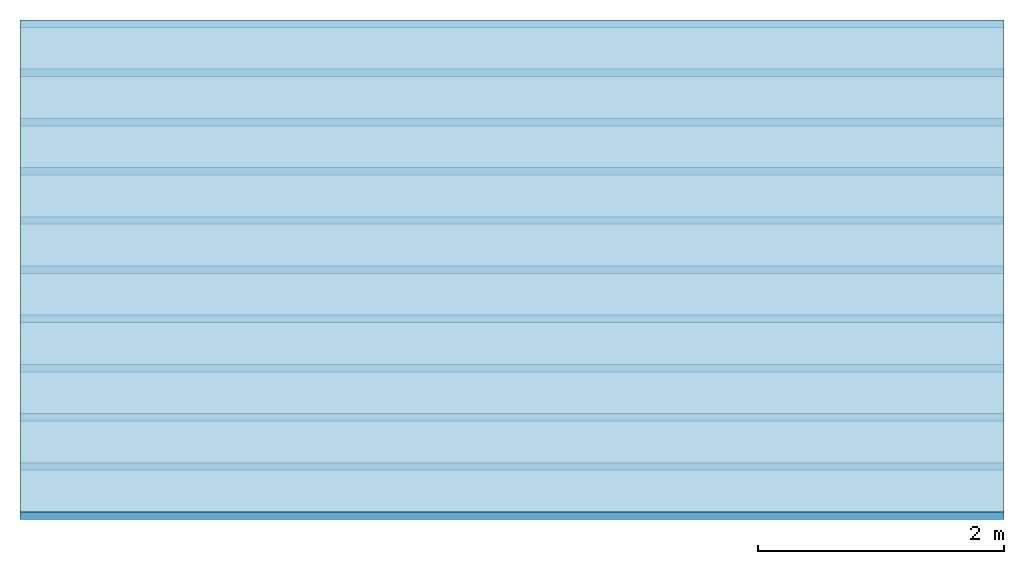
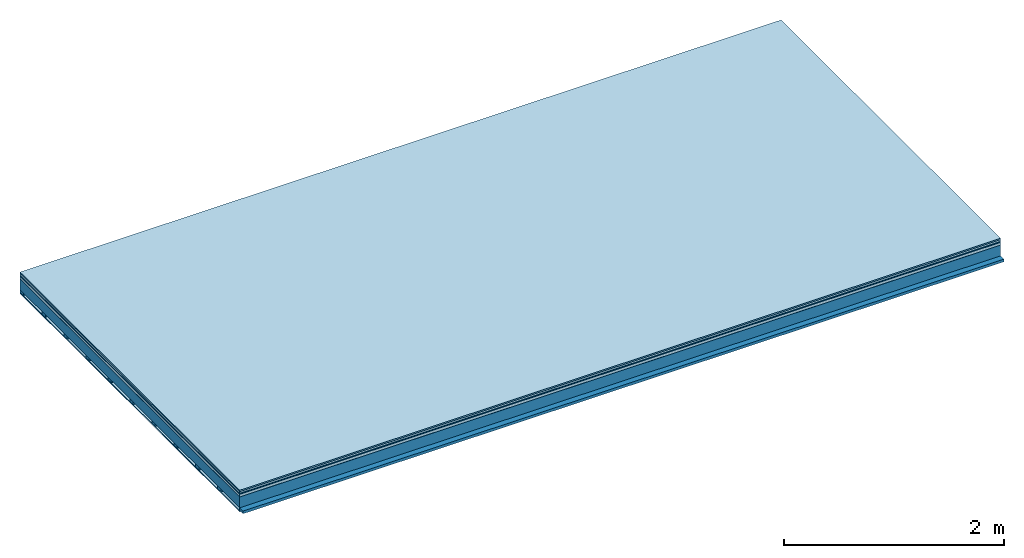
# One storey: 7 plates, 2 members, 1 element without a shape of its own.
"""IFC4 building model written with IfcOpenShell, lengths in metres."""

from ifc_helpers import new_model, si_unit, derived_unit, direction, frame, frame_2d, origin, origin_with_axes, place, context, project, spatial, rectangle, extrude, material, layer, layer_set, type_object, element, aggregate, save


model = new_model("IFC4")

# Units and contexts
plan_context = context("Plan", 3, precision=1e-05, world=origin(), true_north=direction((0.0, 1.0)))
model_context = context("Model", 3, precision=1e-05, world=origin(), true_north=direction((0.0, 1.0)))
ifc_project = project(units=[si_unit("LENGTHUNIT", "METRE"), derived_unit("SOUNDPRESSUREUNIT", [(si_unit("PRESSUREUNIT", "PASCAL", prefix="MICRO"), 0)]), si_unit("ENERGYUNIT", "JOULE", prefix="MEGA"), si_unit("MASSUNIT", "GRAM", prefix="KILO"), derived_unit("THERMALTRANSMITTANCEUNIT", [(si_unit("POWERUNIT", "WATT"), 1), (si_unit("AREAUNIT", "SQUARE_METRE"), -1), (si_unit("THERMODYNAMICTEMPERATUREUNIT", "KELVIN"), -1)]), derived_unit("AREADENSITYUNIT", [(si_unit("MASSUNIT", "GRAM", prefix="KILO"), 1), (si_unit("AREAUNIT", "SQUARE_METRE"), -1)]), derived_unit("USERDEFINED", [(si_unit("ENERGYUNIT", "JOULE", prefix="MEGA"), 1), (si_unit("AREAUNIT", "SQUARE_METRE"), -1)])], contexts=[plan_context, model_context])

# Site, building, storey
site = spatial("IfcSite", under=ifc_project)
building_placement = place(None, origin())
building = spatial("IfcBuilding", under=site, at=building_placement)
storey_placement = place(building_placement, origin())
storey = spatial("IfcBuildingStorey", under=building, at=storey_placement)

# Slab, members, plates
ifc_material_1 = material(Category="11.013")
ifc_layer_1 = layer(ifc_material_1, 0.015, Name="Flooring")
ifc_material_2 = material(Category="03.007")
ifc_layer_2 = layer(ifc_material_2, 0.02, Name="On-material")
ifc_material_3 = material(Name="Wood fiber generic product", Category="10.009")
ifc_layer_3 = layer(ifc_material_3, 0.01, Name="Impact sound insulation")
ifc_material_4 = material(Name="with broken")
ifc_layer_4 = layer(ifc_material_4, 0.03, Name="on Supporting structure")
ifc_material_5 = material(Name="protection", Category="09.007")
ifc_layer_5 = layer(ifc_material_5, 0.0005, Name="Sub-floor")
ifc_material_6 = material(Name="no composite action")
ifc_layer_6 = layer(ifc_material_6, 0.0, Name="Bond")
ifc_layer_7 = layer(None, 0.12, Name="Supporting structure")
ifc_material_7 = material(Name="of the art")
ifc_layer_8 = layer(ifc_material_7, 0.0, Name="Bond")
ifc_layer_9 = layer(None, 0.03, Name="Battens / profiles")
ifc_material_8 = material(Name="Plasterboard type A", Category="03.008")
ifc_layer_10 = layer(ifc_material_8, 0.0125, Name="Ceiling covering 1st layer")
ifc_material_9 = material(Category="04.001")
ifc_layer_11 = layer(ifc_material_9, 0.003, Name="Surface / treatment")
ifc_layer_set = layer_set([ifc_layer_1, ifc_layer_2, ifc_layer_3, ifc_layer_4, ifc_layer_5, ifc_layer_6, ifc_layer_7, ifc_layer_8, ifc_layer_9, ifc_layer_10, ifc_layer_11])
slab_type = type_object("IfcSlabType", Name="A2105", PredefinedType="NOTDEFINED", material=ifc_layer_set)
slab_placement = place(None, frame((0.0, 0.0, 0.0), z_axis=(0.0, 0.0, -1.0), x_axis=(1.0, 0.0, 0.0)))
slab = element("IfcSlab", 1, at=slab_placement, inside=storey, type_object=slab_type, material=ifc_layer_set, Name="Slab #1")
ifc_material_10 = material(Name="Solid timber panel")
member_1_placement = place(slab_placement, origin())
member_1 = element("IfcMember", 2, at=member_1_placement, material=ifc_material_10, Name="Supporting structure", context=plan_context, shape_type="SweptSolid", body=[
    extrude(rectangle(XDim=1.0, YDim=0.12, at=frame_2d((0.5, 0.06), x_axis=(1.0, 0.0))), frame((0.0, 4.0, 0.0755), z_axis=(0.0, -1.0, 0.0), x_axis=(1.0, 0.0, 0.0)), (0.0, 0.0, 1.0), 4.0),
    extrude(rectangle(XDim=1.0, YDim=0.12, at=frame_2d((0.5, 0.06), x_axis=(1.0, 0.0))), frame((1.0, 4.0, 0.0755), z_axis=(0.0, -1.0, 0.0), x_axis=(1.0, 0.0, 0.0)), (0.0, 0.0, 1.0), 4.0),
    extrude(rectangle(XDim=1.0, YDim=0.12, at=frame_2d((0.5, 0.06), x_axis=(1.0, 0.0))), frame((2.0, 4.0, 0.0755), z_axis=(0.0, -1.0, 0.0), x_axis=(1.0, 0.0, 0.0)), (0.0, 0.0, 1.0), 4.0),
    extrude(rectangle(XDim=1.0, YDim=0.12, at=frame_2d((0.5, 0.06), x_axis=(1.0, 0.0))), frame((3.0, 4.0, 0.0755), z_axis=(0.0, -1.0, 0.0), x_axis=(1.0, 0.0, 0.0)), (0.0, 0.0, 1.0), 4.0),
    extrude(rectangle(XDim=1.0, YDim=0.12, at=frame_2d((0.5, 0.06), x_axis=(1.0, 0.0))), frame((4.0, 4.0, 0.0755), z_axis=(0.0, -1.0, 0.0), x_axis=(1.0, 0.0, 0.0)), (0.0, 0.0, 1.0), 4.0),
    extrude(rectangle(XDim=1.0, YDim=0.12, at=frame_2d((0.5, 0.06), x_axis=(1.0, 0.0))), frame((5.0, 4.0, 0.0755), z_axis=(0.0, -1.0, 0.0), x_axis=(1.0, 0.0, 0.0)), (0.0, 0.0, 1.0), 4.0),
    extrude(rectangle(XDim=1.0, YDim=0.12, at=frame_2d((0.5, 0.06), x_axis=(1.0, 0.0))), frame((6.0, 4.0, 0.0755), z_axis=(0.0, -1.0, 0.0), x_axis=(1.0, 0.0, 0.0)), (0.0, 0.0, 1.0), 4.0),
    extrude(rectangle(XDim=1.0, YDim=0.12, at=frame_2d((0.5, 0.06), x_axis=(1.0, 0.0))), frame((7.0, 4.0, 0.0755), z_axis=(0.0, -1.0, 0.0), x_axis=(1.0, 0.0, 0.0)), (0.0, 0.0, 1.0), 4.0),
])
ifc_material_11 = material()
member_2_placement = place(slab_placement, origin())
member_2 = element("IfcMember", 3, at=member_2_placement, material=ifc_material_11, Name="Battens / profiles", context=plan_context, shape_type="SweptSolid", body=[
    extrude(rectangle(XDim=0.06, YDim=0.03, at=frame_2d((0.03, 0.015), x_axis=(1.0, 0.0))), frame((0.0, 0.0, 0.1955), z_axis=(1.0, 0.0, 0.0), x_axis=(0.0, 1.0, 0.0)), (0.0, 0.0, 1.0), 8.0),
    extrude(rectangle(XDim=0.06, YDim=0.03, at=frame_2d((0.03, 0.015), x_axis=(1.0, 0.0))), frame((0.0, 0.4, 0.1955), z_axis=(1.0, 0.0, 0.0), x_axis=(0.0, 1.0, 0.0)), (0.0, 0.0, 1.0), 8.0),
    extrude(rectangle(XDim=0.06, YDim=0.03, at=frame_2d((0.03, 0.015), x_axis=(1.0, 0.0))), frame((0.0, 0.8, 0.1955), z_axis=(1.0, 0.0, 0.0), x_axis=(0.0, 1.0, 0.0)), (0.0, 0.0, 1.0), 8.0),
    extrude(rectangle(XDim=0.06, YDim=0.03, at=frame_2d((0.03, 0.015), x_axis=(1.0, 0.0))), frame((0.0, 1.2, 0.1955), z_axis=(1.0, 0.0, 0.0), x_axis=(0.0, 1.0, 0.0)), (0.0, 0.0, 1.0), 8.0),
    extrude(rectangle(XDim=0.06, YDim=0.03, at=frame_2d((0.03, 0.015), x_axis=(1.0, 0.0))), frame((0.0, 1.6, 0.1955), z_axis=(1.0, 0.0, 0.0), x_axis=(0.0, 1.0, 0.0)), (0.0, 0.0, 1.0), 8.0),
    extrude(rectangle(XDim=0.06, YDim=0.03, at=frame_2d((0.03, 0.015), x_axis=(1.0, 0.0))), frame((0.0, 2.0, 0.1955), z_axis=(1.0, 0.0, 0.0), x_axis=(0.0, 1.0, 0.0)), (0.0, 0.0, 1.0), 8.0),
    extrude(rectangle(XDim=0.06, YDim=0.03, at=frame_2d((0.03, 0.015), x_axis=(1.0, 0.0))), frame((0.0, 2.4, 0.1955), z_axis=(1.0, 0.0, 0.0), x_axis=(0.0, 1.0, 0.0)), (0.0, 0.0, 1.0), 8.0),
    extrude(rectangle(XDim=0.06, YDim=0.03, at=frame_2d((0.03, 0.015), x_axis=(1.0, 0.0))), frame((0.0, 2.8, 0.1955), z_axis=(1.0, 0.0, 0.0), x_axis=(0.0, 1.0, 0.0)), (0.0, 0.0, 1.0), 8.0),
    extrude(rectangle(XDim=0.06, YDim=0.03, at=frame_2d((0.03, 0.015), x_axis=(1.0, 0.0))), frame((0.0, 3.2, 0.1955), z_axis=(1.0, 0.0, 0.0), x_axis=(0.0, 1.0, 0.0)), (0.0, 0.0, 1.0), 8.0),
    extrude(rectangle(XDim=0.06, YDim=0.03, at=frame_2d((0.03, 0.015), x_axis=(1.0, 0.0))), frame((0.0, 3.6, 0.1955), z_axis=(1.0, 0.0, 0.0), x_axis=(0.0, 1.0, 0.0)), (0.0, 0.0, 1.0), 8.0),
    extrude(rectangle(XDim=0.06, YDim=0.03, at=frame_2d((0.03, 0.015), x_axis=(1.0, 0.0))), frame((0.0, 4.0, 0.1955), z_axis=(1.0, 0.0, 0.0), x_axis=(0.0, 1.0, 0.0)), (0.0, 0.0, 1.0), 8.0),
])
plate_1_placement = place(slab_placement, origin())
plate_1 = element("IfcPlate", 4, at=plate_1_placement, material=ifc_material_1, Name="Flooring", context=plan_context, shape_type="SweptSolid", body=[
    extrude(rectangle(XDim=8.0, YDim=4.0, at=frame_2d((4.0, 2.0), x_axis=(1.0, 0.0))), origin_with_axes(), (0.0, 0.0, 1.0), 0.015),
])
plate_2_placement = place(slab_placement, origin())
plate_2 = element("IfcPlate", 5, at=plate_2_placement, material=ifc_material_2, Name="On-material", context=plan_context, shape_type="SweptSolid", body=[
    extrude(rectangle(XDim=8.0, YDim=4.0, at=frame_2d((4.0, 2.0), x_axis=(1.0, 0.0))), frame((0.0, 0.0, 0.015), z_axis=(0.0, 0.0, 1.0), x_axis=(1.0, 0.0, 0.0)), (0.0, 0.0, 1.0), 0.02),
])
plate_3_placement = place(slab_placement, origin())
plate_3 = element("IfcPlate", 6, at=plate_3_placement, material=ifc_material_3, Name="Impact sound insulation", context=plan_context, shape_type="SweptSolid", body=[
    extrude(rectangle(XDim=8.0, YDim=4.0, at=frame_2d((4.0, 2.0), x_axis=(1.0, 0.0))), frame((0.0, 0.0, 0.035), z_axis=(0.0, 0.0, 1.0), x_axis=(1.0, 0.0, 0.0)), (0.0, 0.0, 1.0), 0.01),
])
plate_4_placement = place(slab_placement, origin())
plate_4 = element("IfcPlate", 7, at=plate_4_placement, material=ifc_material_4, Name="on Supporting structure", context=plan_context, shape_type="SweptSolid", body=[
    extrude(rectangle(XDim=8.0, YDim=4.0, at=frame_2d((4.0, 2.0), x_axis=(1.0, 0.0))), frame((0.0, 0.0, 0.045), z_axis=(0.0, 0.0, 1.0), x_axis=(1.0, 0.0, 0.0)), (0.0, 0.0, 1.0), 0.03),
])
plate_5_placement = place(slab_placement, origin())
plate_5 = element("IfcPlate", 8, at=plate_5_placement, material=ifc_material_5, Name="Sub-floor", context=plan_context, shape_type="SweptSolid", body=[
    extrude(rectangle(XDim=8.0, YDim=4.0, at=frame_2d((4.0, 2.0), x_axis=(1.0, 0.0))), frame((0.0, 0.0, 0.075), z_axis=(0.0, 0.0, 1.0), x_axis=(1.0, 0.0, 0.0)), (0.0, 0.0, 1.0), 0.0005),
])
plate_6_placement = place(slab_placement, origin())
plate_6 = element("IfcPlate", 9, at=plate_6_placement, material=ifc_material_8, Name="Ceiling covering 1st layer", context=plan_context, shape_type="SweptSolid", body=[
    extrude(rectangle(XDim=8.0, YDim=4.0, at=frame_2d((4.0, 2.0), x_axis=(1.0, 0.0))), frame((0.0, 0.0, 0.2255), z_axis=(0.0, 0.0, 1.0), x_axis=(1.0, 0.0, 0.0)), (0.0, 0.0, 1.0), 0.0125),
])
plate_7_placement = place(slab_placement, origin())
plate_7 = element("IfcPlate", 10, at=plate_7_placement, material=ifc_material_9, Name="Surface / treatment", context=plan_context, shape_type="SweptSolid", body=[
    extrude(rectangle(XDim=8.0, YDim=4.0, at=frame_2d((4.0, 2.0), x_axis=(1.0, 0.0))), frame((0.0, 0.0, 0.238), z_axis=(0.0, 0.0, 1.0), x_axis=(1.0, 0.0, 0.0)), (0.0, 0.0, 1.0), 0.003),
])
aggregate(slab, [plate_1, plate_2, plate_3, plate_4, plate_5, member_1, member_2, plate_6, plate_7])

save(model, "model.ifc")
